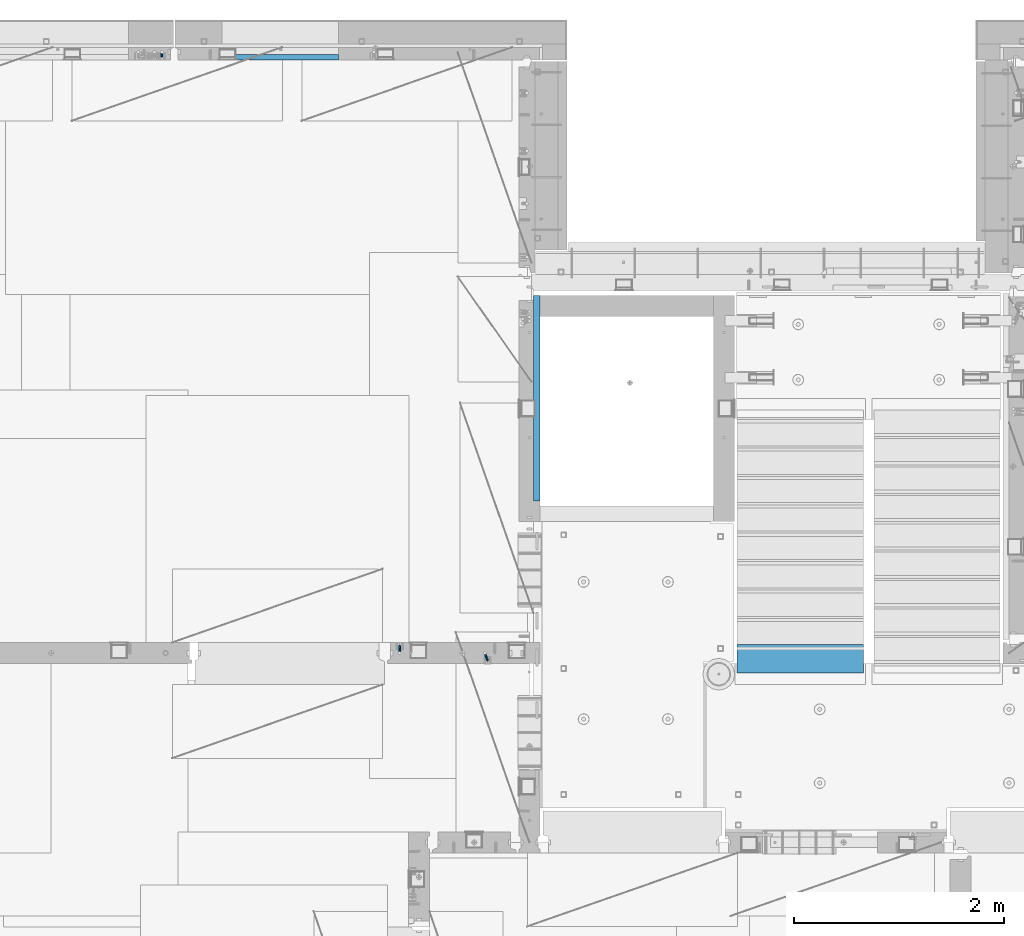
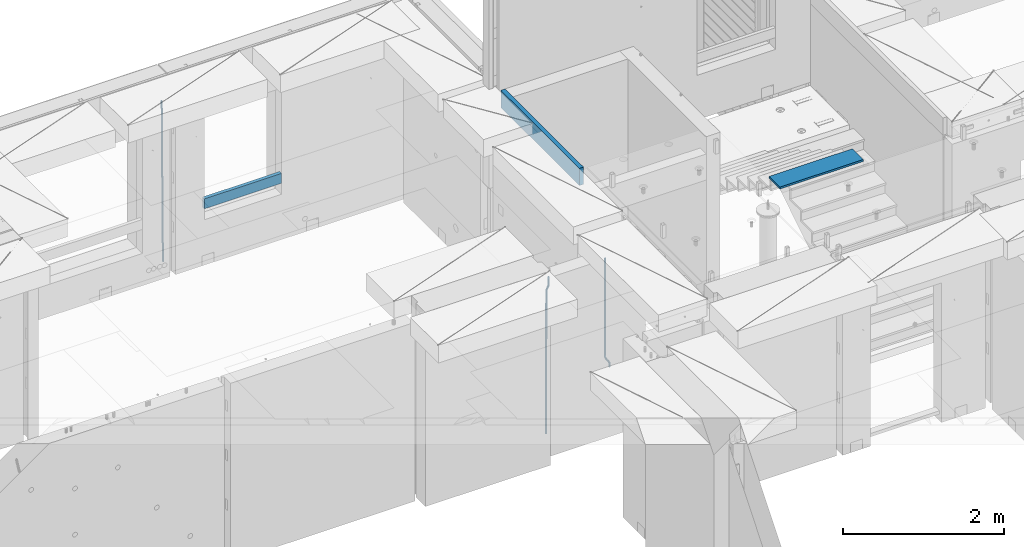
# One storey, part 118 of 349: 6 beams, 5 elements without a shape of their own.
"""IFC2X3 building model written with IfcOpenShell, lengths in millimetres."""

from ifc_helpers import new_model, si_unit, frame, origin_with_axes, place, context, subcontext, project, spatial, faceted_brep, material, type_object, element, aggregate, save


model = new_model("IFC2X3")

# Units and contexts
model_context = context("Model", 3, precision=1e-05, world=origin_with_axes())
body_context = subcontext(model_context, "Body", "Model", "MODEL_VIEW")
ifc_project = project(units=[si_unit("LENGTHUNIT", "METRE", prefix="MILLI"), si_unit("AREAUNIT", "SQUARE_METRE"), si_unit("VOLUMEUNIT", "CUBIC_METRE"), si_unit("MASSUNIT", "GRAM", prefix="KILO"), si_unit("TIMEUNIT", "SECOND"), si_unit("PLANEANGLEUNIT", "RADIAN"), si_unit("SOLIDANGLEUNIT", "STERADIAN"), si_unit("THERMODYNAMICTEMPERATUREUNIT", "DEGREE_CELSIUS"), si_unit("LUMINOUSINTENSITYUNIT", "LUMEN")], contexts=[model_context])

# Site, building, storey
site_placement = place(None, origin_with_axes())
site = spatial("IfcSite", under=ifc_project, at=site_placement, CompositionType="ELEMENT")
building_placement = place(site_placement, origin_with_axes())
building = spatial("IfcBuilding", under=site, at=building_placement, CompositionType="ELEMENT")
storey_placement = place(building_placement, origin_with_axes())
storey = spatial("IfcBuildingStorey", under=building, at=storey_placement, Name="4", CompositionType="ELEMENT", Elevation=0.0)

# Assembly, beams
assembly_1_placement = place(storey_placement, origin_with_axes())
assembly_1 = element("IfcElementAssembly", 1, at=assembly_1_placement, inside=storey, AssemblyPlace="NOTDEFINED", PredefinedType="REINFORCEMENT_UNIT")
ifc_material_1 = material()
beam_type_1 = type_object("IfcBeamType", Name="D20", PredefinedType="NOTDEFINED")
beam_1_placement = place(assembly_1_placement, frame((17285.016478657, 16980.0, 93407.5), z_axis=(-0.000415599999849952, -0.999999913638316, 0.0), x_axis=(-6.05680000062309e-05, -4.00000390151988e-09, -0.999999998165759)))
beam_1 = element("IfcBeam", 2, at=beam_1_placement, type_object=beam_type_1, material=ifc_material_1, Name="JM20", ObjectType="D20", context=body_context, shape_type="Brep", body=[
    faceted_brep([(0.000459931368823163, -9.99999998942076, 0.0), (0.000325058383168653, -7.07106780439426, -7.07106781187031), (1498.53016917036, -7.00214571310062, -7.07110244258729), (1498.53030404639, -9.93107788867201, -3.46394881489687e-05), (0.0, 0.0, -10.0), (1498.52984388257, 0.0689220912790915, -10.0000346307206), (-0.000325382832670584, 7.07106780437971, -7.07106781186667), (1498.52951872915, 7.13998989566971, -7.07110244258365), (-0.000459931412478909, 9.9999999894244, 0.0), (1498.52938418057, 10.0689220807144, -3.46307206200436e-05), (-0.000325058426824398, 7.07106780439062, 7.07106781186667), (1498.52951905355, 7.13998989568427, 7.07103318114605), (0.0, 0.0, 10.0), (1498.52984434133, 0.0689220913009194, 9.99996536927938), (0.000325382789014839, -7.07106780437607, 7.07106781186303), (1498.53016949476, -7.00214571308607, 7.07103318114241), (1512.41720874803, -5.73582294623338, -3.78448857876356), (1509.77427058959, -8.90577003658836, 2.66104918808924), (1506.12781116656, -6.30933666407145, 8.86914963737581), (1503.61387695429, 0.5325217154641, 11.203191722434), (1503.70509651935, 7.6119372551475, 8.29592524499458), (1506.34803467779, 10.7818843455061, 1.85038747814542), (1509.99449410092, 8.18545097300375, -4.35771297110477), (1512.50842831319, 1.34359259344637, -6.6917550561775), (1523.10793428493, 4.85819958866705, 2.43339327473223), (1522.94729923509, -2.24423288682374, 5.28089974098111), (1518.68801206884, 11.068066365151, 3.12656423834051), (1512.27666307625, 12.7477117054659, 6.95436248228361), (1507.62956859401, 8.91322214926913, 11.6745157093537), (1507.46893354415, 1.81078967378926, 14.5220221756208), (1511.88885576031, -4.39907710268017, 13.8288512120525), (1518.30020474852, -6.07872245333419, 10.0010529750907), (1556.47190306216, 16.2553988912259, 53.3150705600565), (1551.82480858495, 12.4209093455574, 58.0352237797015), (1556.63253811194, 23.3578313666767, 50.4675640938258), (1552.2126158958, 29.5676981431861, 51.1607350575687), (1545.80126690332, 31.2473434836029, 54.9885333017664), (1541.1541724212, 27.4128539274789, 59.7086865290003), (1540.99353737144, 20.3104214520208, 62.5561929952273), (1545.41345958759, 14.100554675515, 61.8630220314881), (1560.39637396604, 17.5567067062075, 56.6936612143036), (1557.75345399432, 14.386777545431, 63.1392152562548), (1554.10697584673, 16.9832211248868, 69.3473004384578), (1551.59299696748, 23.8250760096525, 71.6813046576062), (1551.6841720884, 30.9044764000282, 68.7739998967481), (1554.32709206025, 34.0744055607975, 62.3284458548405), (1557.97357020773, 31.4779619813417, 56.1203606726085), (1560.48754908697, 24.6361070965759, 53.7863564534418), (1565.57152260729, 25.0997628321384, 54.9895678972971), (1565.57195097132, 18.0287166318594, 57.9185522284643), (1565.57109441068, 32.1708522292429, 57.9184479422765), (1565.5709172132, 35.0998365550477, 64.9894941556158), (1565.57109481466, 32.1709565155361, 72.0605835657152), (1565.57152317863, 25.0999103152426, 74.9895678968714), (1565.5719513753, 18.0288209181526, 72.0606878518956), (1565.57212857006, 15.0998365824271, 64.9896416479532), (1617.49891294041, 18.0318617339399, 57.9185507229813), (1617.49909054188, 15.1029816944028, 64.9896401330443), (1617.49848457637, 25.1029079342443, 54.989566391796), (1617.49805637961, 32.1739973313524, 57.9184464367172), (1617.49787918197, 35.1029816571718, 64.9894926500019), (1617.49805678344, 32.1741016176347, 72.0605820600649), (1617.49848514747, 25.1030554173267, 74.9895663912539), (1617.49891334424, 18.0319660202294, 72.060686346329)], [[[0, 1, 2, 3]], [[1, 4, 5, 2]], [[4, 6, 7, 5]], [[6, 8, 9, 7]], [[8, 10, 11, 9]], [[10, 12, 13, 11]], [[12, 14, 15, 13]], [[14, 0, 3, 15]], [[14, 12, 10, 8, 6, 4, 1, 0]], [[3, 2, 16, 17]], [[15, 3, 17, 18]], [[13, 15, 18, 19]], [[11, 13, 19, 20]], [[9, 11, 20, 21]], [[7, 9, 21, 22]], [[5, 7, 22, 23]], [[2, 5, 23, 16]], [[23, 24, 25, 16]], [[22, 26, 24, 23]], [[21, 27, 26, 22]], [[20, 28, 27, 21]], [[19, 29, 28, 20]], [[18, 30, 29, 19]], [[17, 31, 30, 18]], [[16, 25, 31, 17]], [[31, 25, 32, 33]], [[25, 24, 34, 32]], [[24, 26, 35, 34]], [[26, 27, 36, 35]], [[27, 28, 37, 36]], [[28, 29, 38, 37]], [[29, 30, 39, 38]], [[30, 31, 33, 39]], [[33, 32, 40, 41]], [[39, 33, 41, 42]], [[38, 39, 42, 43]], [[37, 38, 43, 44]], [[36, 37, 44, 45]], [[35, 36, 45, 46]], [[34, 35, 46, 47]], [[32, 34, 47, 40]], [[47, 48, 49, 40]], [[46, 50, 48, 47]], [[45, 51, 50, 46]], [[44, 52, 51, 45]], [[43, 53, 52, 44]], [[42, 54, 53, 43]], [[41, 55, 54, 42]], [[40, 49, 55, 41]], [[55, 49, 56, 57]], [[49, 48, 58, 56]], [[48, 50, 59, 58]], [[50, 51, 60, 59]], [[51, 52, 61, 60]], [[52, 53, 62, 61]], [[53, 54, 63, 62]], [[54, 55, 57, 63]], [[58, 59, 60, 61, 62, 63, 57, 56]]]),
])
beam_2_placement = place(assembly_1_placement, frame((16475.016478657, 16980.0, 93407.5), z_axis=(-0.000415599999849952, -0.999999913638316, 0.0), x_axis=(-6.05680000062309e-05, -4.00000390151988e-09, -0.999999998165759)))
beam_2 = element("IfcBeam", 3, at=beam_2_placement, type_object=beam_type_1, material=ifc_material_1, Name="JM20", ObjectType="D20", context=body_context, shape_type="Brep", body=[
    faceted_brep([(-0.00060564729210455, -9.99999998165731, 0.0), (-0.000428079845733009, -7.07106779890455, -7.07106781186667), (109.663992146438, -7.07770969181365, -7.07106505070624), (109.663814574931, -10.0066418742208, 2.76014907285571e-06), (0.0, 0.0, -10.0), (109.664420484245, -0.00664189292001538, -9.99999723883957), (0.00042843479604926, 7.07106779888636, -7.07106781186303), (109.66484867355, 7.0644259059809, -7.07106505070988), (0.00060564729210455, 9.99999998166459, 3.63797880709171e-12), (109.665025886861, 9.99335808875549, 2.76115679298528e-06), (0.000428079845733009, 7.07106779890819, 7.07106781186667), (109.664848315049, 7.06442590600273, 7.07107057301982), (0.0, 0.0, 10.0), (109.664419977242, -0.00664189288727357, 10.0000027611604), (-0.000428434810601175, -7.07106779888272, 7.07106781186667), (109.663991787937, -7.07770969179182, 7.07107057302346), (123.019465653822, -0.00769783093346632, 8.49481275451399), (122.368218641306, 7.06342149385819, 5.63932810477127), (120.794596020874, 9.9924781119953, -1.25436342694593), (119.220404581531, 7.06367038153257, -8.14803083615698), (118.567784318744, -0.00734585062309634, -11.0034572490222), (119.219031331319, -7.07846517541839, -8.14797259927946), (120.79265395175, -10.0075217935628, -1.25428106757317), (122.366845391021, -7.07871406308914, 5.63938634164515), (134.432358609134, -7.0801380724879, 1.41616492140383), (135.704448506891, -0.00919495208290755, 4.05476198080942), (131.363125973905, -10.0087693538771, -4.95420191149606), (128.294665451453, -7.07953630984775, -11.3246640276848), (127.024439601548, -0.00834393120385357, -13.9634911148387), (128.296529499246, 7.06259918918295, -11.3248940553931), (131.365762135116, 9.99123047017565, -4.95452722118716), (134.434222657001, 7.06199742654644, 1.41593489364823), (232.333181448281, -7.09406463311461, -61.4435769522424), (235.401641971155, -10.0232976755033, -55.0731148385494), (231.062955598129, -0.0228722546671634, -64.0824040398293), (232.335045495653, 7.04807086590154, -61.4438069808093), (235.404278131435, 9.97670214732716, -55.0734401467271), (238.472738653494, 7.0474691041527, -48.7029780316807), (239.742964503646, -0.0237232742911146, -46.0641509440975), (238.470874606137, -7.09466639485981, -48.7027480031138), (248.152386176487, -0.0244396446978499, -49.0133708264948), (247.497266945589, 7.04670033489674, -51.8679184167595), (245.915123067214, 9.97580676374491, -58.7596380886316), (244.332752967632, 7.04704882145597, -65.6514539264135), (243.677087590491, -0.0239468102772662, -68.5062336817027), (244.33220682136, -7.09508678989368, -65.651686091438), (245.914350699837, -10.0241932187346, -58.7599664195659), (247.496720799376, -7.09543527645292, -51.8681505817658), (256.999396693936, -7.09531210125351, -52.9566469665442), (257.006072236094, -0.0243248818260327, -50.0275278254703), (256.982439129002, -10.0240497531304, -60.0277750206151), (256.965133057005, -7.09492303985826, -67.0987410777925), (256.957616135987, -0.0237746659149707, -70.0274691179584), (256.964291678203, 7.04721255350523, -67.0983499769027), (256.981249241362, 9.97595020465087, -60.027221921624), (256.998555315135, 7.04682349210998, -52.9562558656398), (2308.84129044529, -6.97271028710384, -72.0700484847293), (2308.85859651901, -9.9018369995174, -64.9990824287343), (2308.83377352433, 0.0984380867485015, -74.9987765249425), (2308.84044906651, 7.16942530619053, -72.0696573839123), (2308.85740662973, 10.0981629574344, -64.9985293286554), (2308.87471270347, 7.16903624502447, -57.9275632726531), (2308.88222962443, 0.0978878711684956, -54.9988352324472), (2308.87555408225, -6.9730993482699, -57.9279543734738), (2309.36197244871, -6.97267927451685, -72.0713099986351), (2309.37071429225, -9.90180649703325, -65.000323193126), (2309.3579998037, 0.0984693104364851, -75.0000466259553), (2309.3611234788, 7.16945631832277, -72.0709188794244), (2309.36951366749, 10.0981934592819, -64.9997700670392), (2309.37825551104, 7.16906623676914, -57.9287832615337), (2309.38222815606, 0.0979176518158056, -55.0000466342135), (2309.37910448095, -6.97306935607776, -57.929174380748), (2309.8826559803, -6.97264773775169, -72.0713100117428), (2309.88283356852, -9.90177547898566, -65.0003232060189), (2309.88222762165, 0.0985010618751403, -75.0000466391502), (2309.88179941924, 7.16948785463319, -72.0709188925321), (2309.88162220824, 10.0982244766819, -64.9997700799322), (2309.88179979647, 7.16909673544797, -57.9287832742084), (2309.88222815514, 0.0979479358211393, -55.0000466468009), (2309.88265635754, -6.97303885693691, -57.9291743934191), (2417.50042500655, -6.96612954309967, -72.0713127206036), (2417.50060259478, -9.89525728433364, -65.0003259148798), (2417.49999664789, 0.105019256523519, -75.0000493480147), (2417.49956844548, 7.17600604928157, -72.0709216013965), (2417.49939123449, 10.1047426713303, -64.9997727887931), (2417.49956882271, 7.17561493009634, -57.9287859830729), (2417.49999718138, 0.104466130473156, -55.0000493556618), (2417.50042538378, -6.96652066228489, -57.9291771022799)], [[[0, 1, 2, 3]], [[1, 4, 5, 2]], [[4, 6, 7, 5]], [[6, 8, 9, 7]], [[8, 10, 11, 9]], [[10, 12, 13, 11]], [[12, 14, 15, 13]], [[14, 0, 3, 15]], [[14, 12, 10, 8, 6, 4, 1, 0]], [[11, 13, 16, 17]], [[9, 11, 17, 18]], [[7, 9, 18, 19]], [[5, 7, 19, 20]], [[2, 5, 20, 21]], [[3, 2, 21, 22]], [[15, 3, 22, 23]], [[13, 15, 23, 16]], [[23, 24, 25, 16]], [[22, 26, 24, 23]], [[21, 27, 26, 22]], [[20, 28, 27, 21]], [[19, 29, 28, 20]], [[18, 30, 29, 19]], [[17, 31, 30, 18]], [[16, 25, 31, 17]], [[26, 27, 32, 33]], [[27, 28, 34, 32]], [[28, 29, 35, 34]], [[29, 30, 36, 35]], [[30, 31, 37, 36]], [[31, 25, 38, 37]], [[25, 24, 39, 38]], [[24, 26, 33, 39]], [[37, 38, 40, 41]], [[36, 37, 41, 42]], [[35, 36, 42, 43]], [[34, 35, 43, 44]], [[32, 34, 44, 45]], [[33, 32, 45, 46]], [[39, 33, 46, 47]], [[38, 39, 47, 40]], [[47, 48, 49, 40]], [[46, 50, 48, 47]], [[45, 51, 50, 46]], [[44, 52, 51, 45]], [[43, 53, 52, 44]], [[42, 54, 53, 43]], [[41, 55, 54, 42]], [[40, 49, 55, 41]], [[50, 51, 56, 57]], [[51, 52, 58, 56]], [[52, 53, 59, 58]], [[53, 54, 60, 59]], [[54, 55, 61, 60]], [[55, 49, 62, 61]], [[49, 48, 63, 62]], [[48, 50, 57, 63]], [[57, 56, 64, 65]], [[56, 58, 66, 64]], [[58, 59, 67, 66]], [[59, 60, 68, 67]], [[60, 61, 69, 68]], [[61, 62, 70, 69]], [[62, 63, 71, 70]], [[63, 57, 65, 71]], [[65, 64, 72, 73]], [[64, 66, 74, 72]], [[66, 67, 75, 74]], [[67, 68, 76, 75]], [[68, 69, 77, 76]], [[69, 70, 78, 77]], [[70, 71, 79, 78]], [[71, 65, 73, 79]], [[73, 72, 80, 81]], [[72, 74, 82, 80]], [[74, 75, 83, 82]], [[75, 76, 84, 83]], [[76, 77, 85, 84]], [[77, 78, 86, 85]], [[78, 79, 87, 86]], [[79, 73, 81, 87]], [[82, 83, 84, 85, 86, 87, 81, 80]]]),
])
aggregate(assembly_1, [beam_1, beam_2])

# Assembly, beam
assembly_2_placement = place(storey_placement, origin_with_axes())
assembly_2 = element("IfcElementAssembly", 4, at=assembly_2_placement, inside=storey, AssemblyPlace="NOTDEFINED", PredefinedType="REINFORCEMENT_UNIT")
ifc_material_2 = material(Name="CONCRETE/C25/30")
beam_type_2 = type_object("IfcBeamType", Name="260X60", PredefinedType="NOTDEFINED")
beam_3_placement = place(assembly_2_placement, frame((17779.9999105288, 18424.9992663657, 93600.0), z_axis=(0.0, 0.0, 1.0), x_axis=(0.0, 1.0, 0.0)))
beam_3 = element("IfcBeam", 5, at=beam_3_placement, type_object=beam_type_2, material=ifc_material_2, ObjectType="260X60", context=body_context, shape_type="Brep", body=[
    faceted_brep([(0.0, 30.0, -130.0), (0.0, 30.0, 130.0), (1954.9989445891, 30.0, 130.0), (1954.9989445891, 30.0, -130.0), (0.0, -30.0, 130.0), (1954.9989445891, -30.0, 130.0), (0.0, -30.0, -130.0), (1954.9989445891, -30.0, -130.0)], [[[0, 1, 2, 3]], [[1, 4, 5, 2]], [[4, 6, 7, 5]], [[6, 0, 3, 7]], [[5, 7, 3, 2]], [[6, 4, 1, 0]]]),
])
aggregate(assembly_2, [beam_3])

assembly_3_placement = place(storey_placement, origin_with_axes())
assembly_3 = element("IfcElementAssembly", 6, at=assembly_3_placement, inside=storey, AssemblyPlace="NOTDEFINED", PredefinedType="REINFORCEMENT_UNIT")
beam_type_3 = type_object("IfcBeamType", Name="D25", PredefinedType="NOTDEFINED")
beam_4_placement = place(assembly_3_placement, frame((14215.0000000039, 22654.9999977209, 90990.0), z_axis=(-0.000205762999925498, 0.999642804629538, -0.0267249099901004), x_axis=(4.30000201928125e-08, 0.0267249099948059, 0.999642825806181)))
beam_4 = element("IfcBeam", 7, at=beam_4_placement, type_object=beam_type_3, material=ifc_material_1, Name="JM25", ObjectType="D25", context=body_context, shape_type="Brep", body=[
    faceted_brep([(-7.41420080885291e-08, -12.5, -3.63797880709171e-12), (-6.42030499875546e-08, -10.8253175473074, -6.25000000000364), (60.4103898235917, -10.8253175318459, -6.2499999938409), (60.4103898269532, -12.4999999845422, 6.16273609921336e-09), (-3.70782800018787e-08, -6.25000000000364, -10.8253175473074), (60.4103898202884, -6.24999998454587, -10.8253175411446), (-1.45519152283669e-11, -3.63797880709171e-12, -12.5), (60.4103898179019, 1.54577719513327e-08, -12.4999999938373), (3.70637280866504e-08, 6.25, -10.8253175473074), (60.410389817087, 6.25000001545777, -10.825317541141), (6.42030499875546e-08, 10.8253175473001, -6.25000000000364), (60.410389818062, 10.8253175627578, -6.24999999383726), (7.41420080885291e-08, 12.4999999999927, 0.0), (60.4103898205503, 12.5000000154541, 6.16273609921336e-09), (6.42176019027829e-08, 10.8253175473001, 6.24999999999636), (60.4103898238973, 10.8253175627651, 6.2500000061591), (3.70928319171071e-08, 6.24999999999636, 10.8253175473037), (60.4103898272151, 6.25000001546141, 10.8253175534664), (1.45519152283669e-11, -3.63797880709171e-12, 12.4999999999964), (60.4103898296162, 1.54541339725256e-08, 12.5000000061591), (-3.7049176171422e-08, -6.25000000000364, 10.8253175473001), (60.4103898304165, -6.24999998454587, 10.8253175534701), (-6.41884980723262e-08, -10.8253175473074, 6.25), (60.4103898294561, -10.8253175318459, 6.25000000616637), (61.0324985728803, -10.8253175316895, -6.24999999377542), (60.991802792938, -12.4999999843931, 6.22458173893392e-09), (61.0622854283865, -6.24999998437852, -10.8253175410755), (61.0731819955545, 1.5628756955266e-08, -12.4999999937718), (61.0622685480339, 6.25000001562512, -10.8253175410791), (61.032469335245, 10.8253175629216, -6.24999999377178), (60.9917690322181, 12.5000000156033, 6.22458173893392e-09), (60.9510732522613, 10.8253175629034, 6.25000000621731), (60.9212863967696, 6.25000001558874, 10.8253175535247), (60.9103898296162, 1.55814632307738e-08, 12.5000000062137), (60.9213032771368, -6.24999998441126, 10.8253175535174), (60.9511024898966, -10.8253175317113, 6.25000000621731), (61.6545545670233, -10.8253158516927, -6.24189838219536), (61.573166454793, -12.499998414296, 0.00757164385504439), (61.7141257553885, -6.24999822394238, -10.8168280205282), (61.7359179680789, 1.80548886419274e-06, -12.491368569139), (61.7140919992817, 6.25000177601396, -10.8168282403167), (61.6544960997562, 10.8253192428383, -6.2418987628771), (61.5730989426083, 12.5000015856094, 0.0075712042817031), (61.4917108303925, 10.8253190230062, 6.25704123032847), (61.4321396420273, 6.25000139525582, 10.8319708686649), (61.4103474293224, 1.36582457344048e-06, 12.5065114172721), (61.4321733981196, -6.24999860470052, 10.8319710884571), (61.4917692976451, -10.8253160715249, 6.25704161101385), (176.524302641745, -10.8250056210964, -4.74584321979273), (176.442914529529, -12.4996881836996, 1.50362680625403), (176.583873830095, -6.24968799334965, -9.3207728581292), (176.605666042786, 0.000312036081595579, -10.9953134067364), (176.583840074018, 6.25031200660669, -9.32077307791769), (176.524244174492, 10.8256294734347, -4.74584360047811), (176.44284701733, 12.5003118162058, 1.50362636668069), (176.361458905099, 10.8256292535989, 7.75309639272746), (176.301887716749, 6.25031162585219, 12.3280260310676), (176.280095504058, 0.000311596420942806, 14.0025665796711), (176.301921472827, -6.24968837410415, 12.3280262508561), (176.361517372367, -10.8250058409321, 7.75309677341284), (177.085397012124, -10.8250041057399, -4.73853556792164), (176.983633547483, -12.4996867233749, 1.51066909103247), (177.159881729676, -6.24968643771717, -9.31327097355097), (177.187129580227, 0.000313606451527448, -10.987740468332), (177.159839524218, 6.25031356221734, -9.31327130338468), (177.085323910098, 10.8256309887511, -4.73853613920801), (176.983549136537, 12.5003132764905, 1.51066843136869), (176.881785671867, 10.8256306588555, 7.7598730903228), (176.80730095433, 6.25031299082912, 12.3346084959521), (176.780053103794, 0.000312946667690994, 14.0090779907332), (176.807343159802, -6.2496870091054, 12.3346088257895), (176.881858773908, -10.8250044356355, 7.7598736616128), (177.646431799818, -10.8250018318176, -4.72756919822132), (177.524295146417, -12.4996845320202, 1.52123723245313), (177.735828462886, -6.24968410334986, -9.30201312475765), (177.768531371941, 0.00031596292683389, -10.9763759912421), (177.735777808921, 6.25031589654827, -9.30201361973741), (177.646344064575, 10.8256332626152, -4.72757005553649), (177.524193838486, 12.5003154677688, 1.52123624250817), (177.402057185071, 10.8256327675663, 7.77004267317898), (177.312660521988, 6.2503150390985, 12.3444865997226), (177.279957612933, 0.00031497282179771, 14.0188494661961), (177.312711175953, -6.24968496079964, 12.3444870946951), (177.402144920314, -10.8250023268702, 7.77004353049415), (299.377443161706, -10.8245084454466, -2.34813158632096), (299.255306508276, -12.4991911456491, 3.90067484435349), (299.466839824803, -6.24919071697514, -6.92257551286093), (299.499542733873, 0.0008093492979242, -8.59693837933446), (299.466789170867, 6.250809282923, -6.92257600783341), (299.377355426492, 10.8261266489935, -2.34813244364341), (299.255205200388, 12.5008088541435, 3.90067385440125), (299.133068546944, 10.826126153941, 10.1494802850757), (299.043671883861, 6.25080842546959, 14.7239242116229), (299.010968974762, 0.000808359200163977, 16.3982870780892), (299.043722537797, -6.24919157442127, 14.7239247065918), (299.133156282158, -10.8245089404954, 10.1494811423981), (299.98561436501, -10.8245059804758, -2.33624385599614), (299.97179243555, -12.4991882411778, 3.91467976726199), (299.995742293278, -6.24918857328521, -6.91223722345239), (299.999447243041, 0.000811375455668895, -8.58716690387519), (299.995736475976, 6.25081142679483, -6.91223684201032), (299.985604289133, 10.8261291142808, -2.33624319533556), (299.971750386685, 12.5008117588586, 3.91467993563856), (299.957928457196, 10.8261294971744, 10.1656035610831), (299.947800528913, 6.25081208998381, 14.7415969285394), (299.944095579151, 0.00081214124293183, 16.4165266089549), (299.947806346216, -6.24918791008895, 14.7415965471009), (299.957938533058, -10.8245055975785, 10.1656029004225), (300.593832239858, -10.8245078794353, -2.34543881707941), (300.688302931099, -12.4991904788549, 3.90384712594823), (300.524685350189, -6.24919022474205, -6.92023371784308), (300.499390115292, 0.000809814544481924, -8.59472497713432), (300.524724372954, 6.25080977519247, -6.92023401429469), (300.593899829313, 10.8261272150703, -2.34543933054374), (300.688380976673, 12.5008095210287, 3.90384653304136), (300.782851667915, 10.8261269216127, 10.1531324760799), (300.851998557599, 6.25080926691589, 14.7279273768363), (300.877293792495, 0.000809227632998955, 16.4024186361276), (300.851959534804, -6.24919073302226, 14.7279276732806), (300.782784078474, -10.8245081728965, 10.153132989537), (2293.32930409742, -10.8307295605009, -32.4713622331001), (2293.42377478865, -12.5054121599169, -26.2220762900724), (2293.26015720774, -6.2554119058077, -37.0461571338565), (2293.23486197284, -0.00541186651753378, -38.7206483931477), (2293.26019623051, 6.24458809413409, -37.0461574303008), (2293.32937168686, 10.8199055340046, -32.4713627465644), (2293.42385283421, 12.4945878399631, -26.2220768829684), (2293.51832352545, 10.8199052405434, -19.972790939948), (2293.58747041514, 6.24458758585388, -15.3979960391844), (2293.61276565003, -0.00541245343265473, -13.7235047798931), (2293.58743139236, -6.25541241408428, -15.3979957427327), (2293.51825593603, -10.8307298539585, -19.9727904264691), (2294.0420846676, -10.8307317859326, -32.4821379598216), (2294.03681932652, -12.5054140739521, -26.2313442200393), (2294.06778164886, -6.2554144273563, -37.0583666982457), (2294.10702478497, -0.00541458957013674, -38.7338336404937), (2294.14929890928, 6.24458531819619, -37.0595987724118), (2294.18327670435, 10.8199028679592, -32.4842719748667), (2294.1998538474, 12.4945854171456, -26.2338083683717), (2294.19458850632, 10.819903129126, -19.9830146285858), (2294.16889152506, 6.24458577054975, -15.4067858901581), (2294.12964838895, -0.0054140672327776, -13.7313189479173), (2294.08737426462, -6.2554139749991, -15.4055538159919), (2294.05339646956, -10.8307315247621, -19.9808806135297), (2294.75482297382, -10.84002603931, -32.4726521173216), (2294.64982751427, -12.513407826169, -26.2231856868602), (2294.87535820232, -6.26594539088183, -37.0476186524102), (2294.97913588268, -0.0167870967634371, -38.7222267036377), (2295.0383488692, 6.23299192477134, -37.0477663960555), (2295.03713108998, 10.8087684320271, -32.4729080168181), (2294.97580884799, 12.4844668051373, -26.2234811741473), (2294.87081338844, 10.8110850182784, -19.9740147436787), (2294.7502781599, 6.23700436985018, -15.3990482086047), (2294.64650047956, -0.0121539242718427, -13.7244401573698), (2294.58728749304, -6.26193294580662, -15.3989004649666), (2294.58850527227, -10.8377094530588, -19.9737588441894), (2316.44667268227, -11.1228921988077, -32.1839550346631), (2316.34167722271, -12.7962739856739, -25.9344886042054), (2316.56720791078, -6.54881155039038, -36.7589215697517), (2316.67098559113, -0.299653256264719, -38.4335296209792), (2316.73019857766, 5.95012576527006, -36.759069313397), (2316.72898079845, 10.5259022725259, -32.1842109341669), (2316.66765855643, 12.2016006456361, -25.9347840914961), (2316.56266309689, 10.5282188587698, -19.6853176610275), (2316.44212786836, 5.95413821035254, -15.1103511259389), (2316.33835018802, -0.295020083769487, -13.4357430747186), (2316.27913720149, -6.54479910530426, -15.1102033823008), (2316.28035498071, -11.1205756125637, -19.685061761531), (2317.13234804722, -11.1318335458927, -32.1748293731798), (2317.04181141085, -12.8054038787741, -25.9251705100723), (2317.2154741603, -6.5572650749491, -36.7502937866229), (2317.26891617525, -0.307450393454928, -38.4255717558117), (2317.27835434731, 5.94297770185585, -36.7517739018112), (2317.24125972588, 10.5192220504723, -32.1773930078925), (2317.16757178486, 12.1950816748285, -25.9281307404563), (2317.0770351485, 10.5215113419545, -19.6784718773561), (2316.99390903539, 5.94694287101083, -15.1030074639057), (2316.94046702047, -0.302871810494253, -13.4277294947169), (2316.9310288484, -6.55329990579412, -15.1015273487101), (2316.96812346982, -11.1295442544142, -19.6759082426288), (2317.81808136747, -11.1298054502913, -32.1659056455355), (2317.74200467508, -12.803315894289, -25.9160547315114), (2317.86379538118, -6.55536082026447, -36.7418676070083), (2317.8668976831, -0.305700748642266, -38.417815303761), (2317.82655701396, 5.94458339541234, -36.7446799039099), (2317.75358262347, 10.5207330230332, -32.1707766866384), (2317.66752794063, 12.1965725370646, -25.9216793252963), (2317.59145124823, 10.5230620930706, -19.6718284112721), (2317.54573723453, 5.94861746304377, -15.0958664497994), (2317.54263493262, -0.301042608574789, -13.4199187530394), (2317.58297560175, -6.55132675263303, -15.0930541529051), (2317.65594999224, -11.1274763802539, -19.6669573701693), (2417.81884292323, -10.831603083323, -30.8687911350135), (2417.74276623082, -12.505113527317, -24.618940220982), (2417.86455693691, -6.25715845329614, -35.4447530964935), (2417.86765923884, -0.00749838167394046, -37.1207007932499), (2417.82731856969, 6.24278576237703, -35.4475653933878), (2417.75434417921, 10.8189353900088, -30.8736621761236), (2417.66828949639, 12.494774904033, -24.6245648147851), (2417.59221280397, 10.8212644600353, -18.3747139007501), (2417.54649879028, 6.2468198300121, -13.79875193927), (2417.54339648837, -0.00284024161010166, -12.1228042425173), (2417.5837371575, -6.25312438566107, -13.795939642383), (2417.65671154798, -10.8292740132893, -18.3698428596399)], [[[0, 1, 2, 3]], [[1, 4, 5, 2]], [[4, 6, 7, 5]], [[6, 8, 9, 7]], [[8, 10, 11, 9]], [[10, 12, 13, 11]], [[12, 14, 15, 13]], [[14, 16, 17, 15]], [[16, 18, 19, 17]], [[18, 20, 21, 19]], [[20, 22, 23, 21]], [[22, 0, 3, 23]], [[22, 20, 18, 16, 14, 12, 10, 8, 6, 4, 1, 0]], [[3, 2, 24, 25]], [[2, 5, 26, 24]], [[5, 7, 27, 26]], [[7, 9, 28, 27]], [[9, 11, 29, 28]], [[11, 13, 30, 29]], [[13, 15, 31, 30]], [[15, 17, 32, 31]], [[17, 19, 33, 32]], [[19, 21, 34, 33]], [[21, 23, 35, 34]], [[23, 3, 25, 35]], [[25, 24, 36, 37]], [[24, 26, 38, 36]], [[26, 27, 39, 38]], [[27, 28, 40, 39]], [[28, 29, 41, 40]], [[29, 30, 42, 41]], [[30, 31, 43, 42]], [[31, 32, 44, 43]], [[32, 33, 45, 44]], [[33, 34, 46, 45]], [[34, 35, 47, 46]], [[35, 25, 37, 47]], [[37, 36, 48, 49]], [[36, 38, 50, 48]], [[38, 39, 51, 50]], [[39, 40, 52, 51]], [[40, 41, 53, 52]], [[41, 42, 54, 53]], [[42, 43, 55, 54]], [[43, 44, 56, 55]], [[44, 45, 57, 56]], [[45, 46, 58, 57]], [[46, 47, 59, 58]], [[47, 37, 49, 59]], [[49, 48, 60, 61]], [[48, 50, 62, 60]], [[50, 51, 63, 62]], [[51, 52, 64, 63]], [[52, 53, 65, 64]], [[53, 54, 66, 65]], [[54, 55, 67, 66]], [[55, 56, 68, 67]], [[56, 57, 69, 68]], [[57, 58, 70, 69]], [[58, 59, 71, 70]], [[59, 49, 61, 71]], [[61, 60, 72, 73]], [[60, 62, 74, 72]], [[62, 63, 75, 74]], [[63, 64, 76, 75]], [[64, 65, 77, 76]], [[65, 66, 78, 77]], [[66, 67, 79, 78]], [[67, 68, 80, 79]], [[68, 69, 81, 80]], [[69, 70, 82, 81]], [[70, 71, 83, 82]], [[71, 61, 73, 83]], [[73, 72, 84, 85]], [[72, 74, 86, 84]], [[74, 75, 87, 86]], [[75, 76, 88, 87]], [[76, 77, 89, 88]], [[77, 78, 90, 89]], [[78, 79, 91, 90]], [[79, 80, 92, 91]], [[80, 81, 93, 92]], [[81, 82, 94, 93]], [[82, 83, 95, 94]], [[83, 73, 85, 95]], [[85, 84, 96, 97]], [[84, 86, 98, 96]], [[86, 87, 99, 98]], [[87, 88, 100, 99]], [[88, 89, 101, 100]], [[89, 90, 102, 101]], [[90, 91, 103, 102]], [[91, 92, 104, 103]], [[92, 93, 105, 104]], [[93, 94, 106, 105]], [[94, 95, 107, 106]], [[95, 85, 97, 107]], [[97, 96, 108, 109]], [[96, 98, 110, 108]], [[98, 99, 111, 110]], [[99, 100, 112, 111]], [[100, 101, 113, 112]], [[101, 102, 114, 113]], [[102, 103, 115, 114]], [[103, 104, 116, 115]], [[104, 105, 117, 116]], [[105, 106, 118, 117]], [[106, 107, 119, 118]], [[107, 97, 109, 119]], [[109, 108, 120, 121]], [[108, 110, 122, 120]], [[110, 111, 123, 122]], [[111, 112, 124, 123]], [[112, 113, 125, 124]], [[113, 114, 126, 125]], [[114, 115, 127, 126]], [[115, 116, 128, 127]], [[116, 117, 129, 128]], [[117, 118, 130, 129]], [[118, 119, 131, 130]], [[119, 109, 121, 131]], [[121, 120, 132, 133]], [[120, 122, 134, 132]], [[122, 123, 135, 134]], [[123, 124, 136, 135]], [[124, 125, 137, 136]], [[125, 126, 138, 137]], [[126, 127, 139, 138]], [[127, 128, 140, 139]], [[128, 129, 141, 140]], [[129, 130, 142, 141]], [[130, 131, 143, 142]], [[131, 121, 133, 143]], [[133, 132, 144, 145]], [[132, 134, 146, 144]], [[134, 135, 147, 146]], [[135, 136, 148, 147]], [[136, 137, 149, 148]], [[137, 138, 150, 149]], [[138, 139, 151, 150]], [[139, 140, 152, 151]], [[140, 141, 153, 152]], [[141, 142, 154, 153]], [[142, 143, 155, 154]], [[143, 133, 145, 155]], [[145, 144, 156, 157]], [[144, 146, 158, 156]], [[146, 147, 159, 158]], [[147, 148, 160, 159]], [[148, 149, 161, 160]], [[149, 150, 162, 161]], [[150, 151, 163, 162]], [[151, 152, 164, 163]], [[152, 153, 165, 164]], [[153, 154, 166, 165]], [[154, 155, 167, 166]], [[155, 145, 157, 167]], [[157, 156, 168, 169]], [[156, 158, 170, 168]], [[158, 159, 171, 170]], [[159, 160, 172, 171]], [[160, 161, 173, 172]], [[161, 162, 174, 173]], [[162, 163, 175, 174]], [[163, 164, 176, 175]], [[164, 165, 177, 176]], [[165, 166, 178, 177]], [[166, 167, 179, 178]], [[167, 157, 169, 179]], [[169, 168, 180, 181]], [[168, 170, 182, 180]], [[170, 171, 183, 182]], [[171, 172, 184, 183]], [[172, 173, 185, 184]], [[173, 174, 186, 185]], [[174, 175, 187, 186]], [[175, 176, 188, 187]], [[176, 177, 189, 188]], [[177, 178, 190, 189]], [[178, 179, 191, 190]], [[179, 169, 181, 191]], [[181, 180, 192, 193]], [[180, 182, 194, 192]], [[182, 183, 195, 194]], [[183, 184, 196, 195]], [[184, 185, 197, 196]], [[185, 186, 198, 197]], [[186, 187, 199, 198]], [[187, 188, 200, 199]], [[188, 189, 201, 200]], [[189, 190, 202, 201]], [[190, 191, 203, 202]], [[191, 181, 193, 203]], [[194, 195, 196, 197, 198, 199, 200, 201, 202, 203, 193, 192]]]),
])
aggregate(assembly_3, [beam_4])

assembly_4_placement = place(storey_placement, origin_with_axes())
assembly_4 = element("IfcElementAssembly", 8, at=assembly_4_placement, inside=storey, AssemblyPlace="NOTDEFINED", PredefinedType="REINFORCEMENT_UNIT")
ifc_material_3 = material(Name="TIMBER/T24")
beam_type_4 = type_object("IfcBeamType", PredefinedType="NOTDEFINED")
beam_5_placement = place(assembly_4_placement, frame((15895.0002989914, 22644.9998418812, 91685.0), z_axis=(0.0, 0.0, 1.0), x_axis=(-1.0, 3.00000001838171e-08, 0.0)))
beam_5 = element("IfcBeam", 9, at=beam_5_placement, type_object=beam_type_4, material=ifc_material_3, context=body_context, shape_type="Brep", body=[
    faceted_brep([(-3.63797880709171e-12, 24.9999999999964, -75.0), (-3.63797880709171e-12, 24.9999999999964, 75.0), (1110.0, 24.9999999999964, 75.0), (1110.0, 24.9999999999964, -75.0), (0.0, -25.0000000000073, 75.0), (1110.0, -25.0000000000073, 75.0), (0.0, -25.0000000000073, -75.0), (1110.0, -25.0000000000073, -75.0)], [[[0, 1, 2, 3]], [[1, 4, 5, 2]], [[4, 6, 7, 5]], [[6, 0, 3, 7]], [[5, 7, 3, 2]], [[6, 4, 1, 0]]]),
])
aggregate(assembly_4, [beam_5])

assembly_5_placement = place(storey_placement, origin_with_axes())
assembly_5 = element("IfcElementAssembly", 10, at=assembly_5_placement, inside=storey, Name="E9", AssemblyPlace="NOTDEFINED", PredefinedType="NOTDEFINED")
ifc_material_4 = material(Name="Undefined/C32/40")
beam_type_5 = type_object("IfcBeamType", PredefinedType="NOTDEFINED")
beam_6_placement = place(assembly_5_placement, frame((20885.0002457424, 16924.9998138874, 93745.3), z_axis=(0.0, 1.0, 0.0), x_axis=(-1.0, 3.00000001838171e-08, 0.0)))
beam_6 = element("IfcBeam", 11, at=beam_6_placement, type_object=beam_type_5, material=ifc_material_4, Name="E9", context=body_context, shape_type="Brep", body=[
    faceted_brep([(0.0, 15.0, -135.0), (0.0, 15.0, 135.0), (1200.0, 15.0, 135.0), (1200.0, 15.0, -135.0), (0.0, -15.0, 135.0), (1200.0, -15.0, 135.0), (0.0, -15.0, -135.0), (1200.0, -15.0, -135.0)], [[[0, 1, 2, 3]], [[1, 4, 5, 2]], [[4, 6, 7, 5]], [[6, 0, 3, 7]], [[5, 7, 3, 2]], [[6, 4, 1, 0]]]),
])
aggregate(assembly_5, [beam_6])

save(model, "model.ifc")
